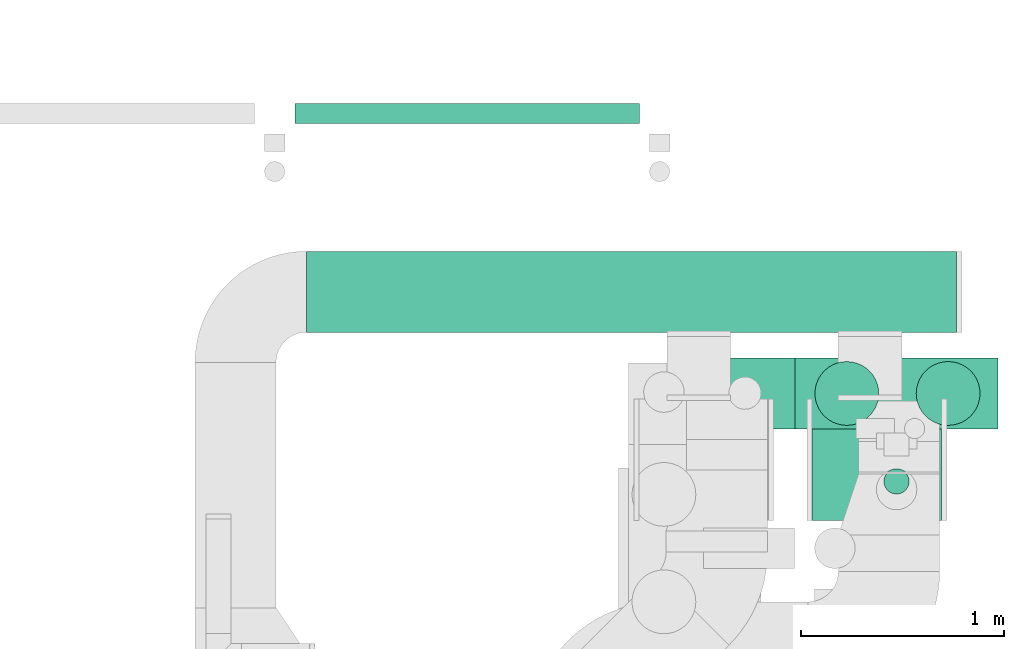
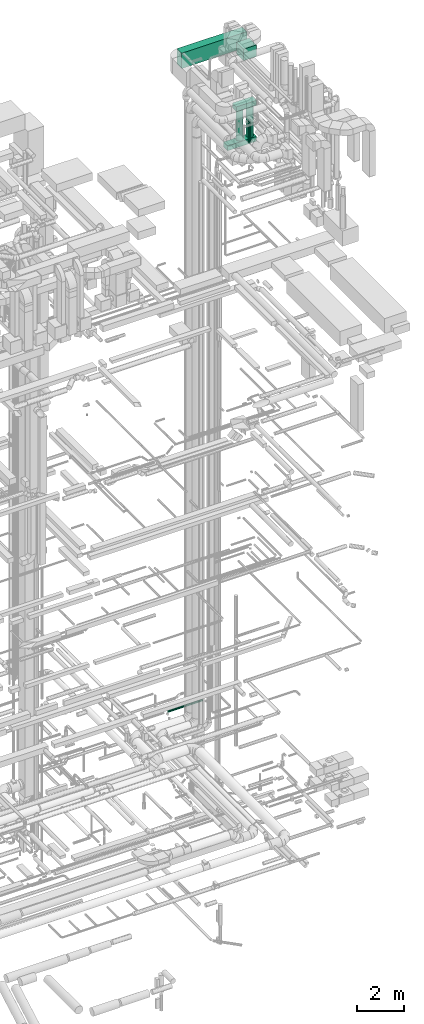
# One storey, part 85 of 337: 8 flow segments.
"""IFC2X3 building model written with IfcOpenShell, lengths in millimetres."""

from ifc_helpers import new_model, entity, si_unit, converted_unit, derived_unit, direction, frame, origin, origin_2d_with_axis, place, context, subcontext, project, spatial, rectangle, circle, extrude, type_object, element, save


model = new_model("IFC2X3")

# Units and contexts
model_context = context("Model", 3, precision=0.01, world=origin(), true_north=direction((6.12303176911189e-17, 1.0)))
body_context = subcontext(model_context, "Body", "Model", "MODEL_VIEW")
ifc_project = project(units=[si_unit("LENGTHUNIT", "METRE", prefix="MILLI"), si_unit("AREAUNIT", "SQUARE_METRE"), si_unit("VOLUMEUNIT", "CUBIC_METRE"), converted_unit("PLANEANGLEUNIT", "DEGREE", entity("IfcRatioMeasure", 0.0174532925199433), si_unit("PLANEANGLEUNIT", "RADIAN"), dimensions=[0, 0, 0, 0, 0, 0, 0]), si_unit("MASSUNIT", "GRAM", prefix="KILO"), derived_unit("MASSDENSITYUNIT", [(si_unit("MASSUNIT", "GRAM", prefix="KILO"), 1), (si_unit("LENGTHUNIT", "METRE"), -3)]), derived_unit("MOMENTOFINERTIAUNIT", [(si_unit("LENGTHUNIT", "METRE"), 4)]), si_unit("TIMEUNIT", "SECOND"), si_unit("FREQUENCYUNIT", "HERTZ"), si_unit("THERMODYNAMICTEMPERATUREUNIT", "DEGREE_CELSIUS"), derived_unit("THERMALTRANSMITTANCEUNIT", [(si_unit("MASSUNIT", "GRAM", prefix="KILO"), 1), (si_unit("THERMODYNAMICTEMPERATUREUNIT", "KELVIN"), -1), (si_unit("TIMEUNIT", "SECOND"), -3)]), derived_unit("VOLUMETRICFLOWRATEUNIT", [(si_unit("LENGTHUNIT", "METRE"), 3), (si_unit("TIMEUNIT", "SECOND"), -1)]), derived_unit("MASSFLOWRATEUNIT", [(si_unit("MASSUNIT", "GRAM", prefix="KILO"), 1), (si_unit("TIMEUNIT", "SECOND"), -1)]), derived_unit("ROTATIONALFREQUENCYUNIT", [(si_unit("TIMEUNIT", "SECOND"), -1)]), si_unit("ELECTRICCURRENTUNIT", "AMPERE"), si_unit("ELECTRICVOLTAGEUNIT", "VOLT"), si_unit("POWERUNIT", "WATT"), si_unit("FORCEUNIT", "NEWTON", prefix="KILO"), si_unit("ILLUMINANCEUNIT", "LUX"), si_unit("LUMINOUSFLUXUNIT", "LUMEN"), si_unit("LUMINOUSINTENSITYUNIT", "CANDELA"), derived_unit("USERDEFINED", [(si_unit("MASSUNIT", "GRAM", prefix="KILO"), -1), (si_unit("LENGTHUNIT", "METRE"), -2), (si_unit("TIMEUNIT", "SECOND"), 3), (si_unit("LUMINOUSFLUXUNIT", "LUMEN"), 1)]), derived_unit("LINEARVELOCITYUNIT", [(si_unit("LENGTHUNIT", "METRE"), 1), (si_unit("TIMEUNIT", "SECOND"), -1)]), si_unit("PRESSUREUNIT", "PASCAL"), derived_unit("USERDEFINED", [(si_unit("LENGTHUNIT", "METRE"), -2), (si_unit("MASSUNIT", "GRAM", prefix="KILO"), 1), (si_unit("TIMEUNIT", "SECOND"), -2)]), derived_unit("LINEARFORCEUNIT", [(si_unit("MASSUNIT", "GRAM", prefix="KILO"), 1), (si_unit("LENGTHUNIT", "METRE"), 1), (si_unit("TIMEUNIT", "SECOND"), -2), (si_unit("LENGTHUNIT", "METRE"), -1)]), derived_unit("PLANARFORCEUNIT", [(si_unit("MASSUNIT", "GRAM", prefix="KILO"), 1), (si_unit("LENGTHUNIT", "METRE"), 1), (si_unit("TIMEUNIT", "SECOND"), -2), (si_unit("LENGTHUNIT", "METRE"), -2)])], contexts=[model_context])

# Site, building, storey
site_placement = place(None, origin())
site = spatial("IfcSite", under=ifc_project, at=site_placement, CompositionType="ELEMENT")
building_placement = place(site_placement, origin())
building = spatial("IfcBuilding", under=site, at=building_placement, CompositionType="ELEMENT")
storey_placement = place(building_placement, origin())
storey = spatial("IfcBuildingStorey", under=building, at=storey_placement, CompositionType="ELEMENT", Elevation=0.0)

# Flow segments
duct_segment_type_1 = type_object("IfcDuctSegmentType", PredefinedType="NOTDEFINED")
flow_segment_1_placement = place(storey_placement, frame((69805.37, 16943.61, 33150.0)))
element("IfcFlowSegment", 1, at=flow_segment_1_placement, inside=storey, type_object=duct_segment_type_1, context=body_context, shape_type="SweptSolid", body=[
    extrude(rectangle(XDim=3210.00000000003, YDim=400.0, at=origin_2d_with_axis()), frame((1605.0, 200.0, 0.0)), (0.0, 0.0, 1.0), 800.0),
])
flow_segment_2_placement = place(storey_placement, frame((71778.06, 16466.7, 28475.0)))
element("IfcFlowSegment", 2, at=flow_segment_2_placement, inside=storey, type_object=duct_segment_type_1, context=body_context, shape_type="SweptSolid", body=[
    extrude(rectangle(XDim=1440.0, YDim=350.000000000001, at=origin_2d_with_axis()), frame((720.0, 175.0, 0.0), z_axis=(0.0, 0.0, 1.0), x_axis=(-1.0, 0.0, 0.0)), (0.0, 0.0, 1.0), 250.000000000004),
])
flow_segment_3_placement = place(storey_placement, frame((72218.06, 16466.7, 30350.0)))
element("IfcFlowSegment", 3, at=flow_segment_3_placement, inside=storey, type_object=duct_segment_type_1, context=body_context, shape_type="SweptSolid", body=[
    extrude(rectangle(XDim=999.999999999998, YDim=350.000000000001, at=origin_2d_with_axis()), frame((500.0, 175.0, 0.0), z_axis=(0.0, 0.0, 1.0), x_axis=(-1.0, 0.0, 0.0)), (0.0, 0.0, 1.0), 250.000000000004),
])
flow_segment_4_placement = place(storey_placement, frame((72301.11, 16013.61, 33250.0)))
element("IfcFlowSegment", 4, at=flow_segment_4_placement, inside=storey, type_object=duct_segment_type_1, context=body_context, shape_type="SweptSolid", body=[
    extrude(rectangle(XDim=640.000000000002, YDim=600.0, at=origin_2d_with_axis()), frame((320.0, 300.0, 0.0)), (0.0, 0.0, 1.0), 600.000000000002),
])
duct_segment_type_2 = type_object("IfcDuctSegmentType", PredefinedType="NOTDEFINED")
flow_segment_5_placement = place(storey_placement, frame((69748.96, 17971.54, -951.6)))
element("IfcFlowSegment", 5, at=flow_segment_5_placement, inside=storey, type_object=duct_segment_type_2, context=body_context, shape_type="SweptSolid", body=[
    extrude(circle(Radius=50.0, at=origin_2d_with_axis()), frame((0.0, 51.6, 51.6), z_axis=(1.0, 0.0, 0.0), x_axis=(0.0, -1.0, 0.0)), (0.0, 0.0, 1.0), 1699.99980000001),
])
for number, where in (
    (6, (72313.81, 16482.6, 28745.0)),
    (7, (72813.81, 16482.6, 28745.0)),
):
    element("IfcFlowSegment", number, at=place(storey_placement, frame(where)), inside=storey, type_object=duct_segment_type_2, context=body_context, shape_type="SweptSolid", body=[
        extrude(circle(Radius=157.5, at=origin_2d_with_axis()), frame((159.1, 159.1, 0.0), z_axis=(0.0, 0.0, 1.0), x_axis=(-1.0, 0.0, 0.0)), (0.0, 0.0, 1.0), 1584.99999988211),
    ])
flow_segment_6_placement = place(storey_placement, frame((72653.96, 16143.65, 28725.0)))
element("IfcFlowSegment", 8, at=flow_segment_6_placement, inside=storey, type_object=duct_segment_type_2, context=body_context, shape_type="SweptSolid", body=[
    extrude(circle(Radius=62.5, at=origin_2d_with_axis()), frame((64.1, 64.1, 0.0), z_axis=(0.0, 0.0, 1.0), x_axis=(-1.0, 0.0, 0.0)), (0.0, 0.0, 1.0), 1180.0),
])

save(model, "model.ifc")
